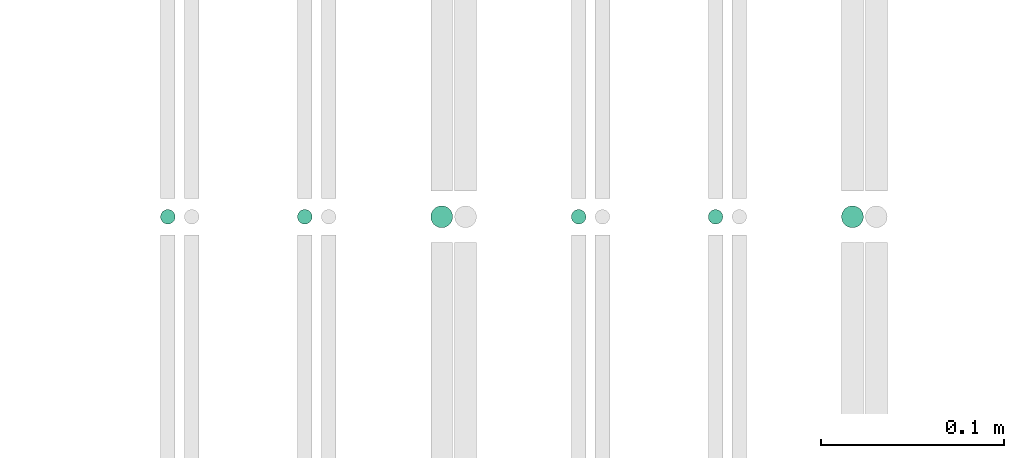
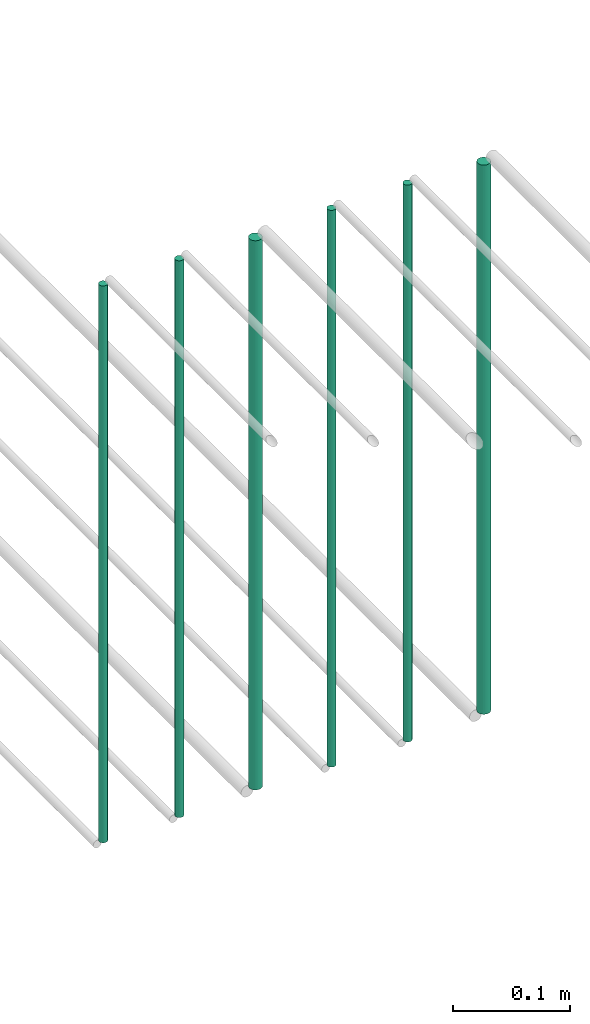
# One storey, part 145 of 331: 6 flow segments.
"""IFC2X3 building model written with IfcOpenShell, lengths in millimetres."""

from ifc_helpers import new_model, entity, si_unit, converted_unit, derived_unit, direction, frame, frame_2d, origin, origin_2d_with_axis, place, context, subcontext, project, spatial, circle, extrude, type_object, element, save


model = new_model("IFC2X3")

# Units and contexts
model_context = context("Model", 3, precision=0.01, world=origin(), true_north=direction((6.12303176911189e-17, 1.0)))
body_context = subcontext(model_context, "Body", "Model", "MODEL_VIEW")
ifc_project = project(units=[si_unit("LENGTHUNIT", "METRE", prefix="MILLI"), si_unit("AREAUNIT", "SQUARE_METRE"), si_unit("VOLUMEUNIT", "CUBIC_METRE"), converted_unit("PLANEANGLEUNIT", "DEGREE", entity("IfcRatioMeasure", 0.0174532925199433), si_unit("PLANEANGLEUNIT", "RADIAN"), dimensions=[0, 0, 0, 0, 0, 0, 0]), si_unit("MASSUNIT", "GRAM", prefix="KILO"), derived_unit("MASSDENSITYUNIT", [(si_unit("MASSUNIT", "GRAM", prefix="KILO"), 1), (si_unit("LENGTHUNIT", "METRE"), -3)]), derived_unit("MOMENTOFINERTIAUNIT", [(si_unit("LENGTHUNIT", "METRE"), 4)]), si_unit("TIMEUNIT", "SECOND"), si_unit("FREQUENCYUNIT", "HERTZ"), si_unit("THERMODYNAMICTEMPERATUREUNIT", "DEGREE_CELSIUS"), derived_unit("THERMALTRANSMITTANCEUNIT", [(si_unit("MASSUNIT", "GRAM", prefix="KILO"), 1), (si_unit("THERMODYNAMICTEMPERATUREUNIT", "KELVIN"), -1), (si_unit("TIMEUNIT", "SECOND"), -3)]), derived_unit("VOLUMETRICFLOWRATEUNIT", [(si_unit("LENGTHUNIT", "METRE"), 3), (si_unit("TIMEUNIT", "SECOND"), -1)]), derived_unit("MASSFLOWRATEUNIT", [(si_unit("MASSUNIT", "GRAM", prefix="KILO"), 1), (si_unit("TIMEUNIT", "SECOND"), -1)]), derived_unit("ROTATIONALFREQUENCYUNIT", [(si_unit("TIMEUNIT", "SECOND"), -1)]), si_unit("ELECTRICCURRENTUNIT", "AMPERE"), si_unit("ELECTRICVOLTAGEUNIT", "VOLT"), si_unit("POWERUNIT", "WATT"), si_unit("FORCEUNIT", "NEWTON", prefix="KILO"), si_unit("ILLUMINANCEUNIT", "LUX"), si_unit("LUMINOUSFLUXUNIT", "LUMEN"), si_unit("LUMINOUSINTENSITYUNIT", "CANDELA"), derived_unit("USERDEFINED", [(si_unit("MASSUNIT", "GRAM", prefix="KILO"), -1), (si_unit("LENGTHUNIT", "METRE"), -2), (si_unit("TIMEUNIT", "SECOND"), 3), (si_unit("LUMINOUSFLUXUNIT", "LUMEN"), 1)]), derived_unit("LINEARVELOCITYUNIT", [(si_unit("LENGTHUNIT", "METRE"), 1), (si_unit("TIMEUNIT", "SECOND"), -1)]), si_unit("PRESSUREUNIT", "PASCAL"), derived_unit("USERDEFINED", [(si_unit("LENGTHUNIT", "METRE"), -2), (si_unit("MASSUNIT", "GRAM", prefix="KILO"), 1), (si_unit("TIMEUNIT", "SECOND"), -2)]), derived_unit("LINEARFORCEUNIT", [(si_unit("MASSUNIT", "GRAM", prefix="KILO"), 1), (si_unit("LENGTHUNIT", "METRE"), 1), (si_unit("TIMEUNIT", "SECOND"), -2), (si_unit("LENGTHUNIT", "METRE"), -1)]), derived_unit("PLANARFORCEUNIT", [(si_unit("MASSUNIT", "GRAM", prefix="KILO"), 1), (si_unit("LENGTHUNIT", "METRE"), 1), (si_unit("TIMEUNIT", "SECOND"), -2), (si_unit("LENGTHUNIT", "METRE"), -2)])], contexts=[model_context])

# Site, building, storey
site_placement = place(None, frame((0.0, -0.00077364408347762, 0.0)))
site = spatial("IfcSite", under=ifc_project, at=site_placement, CompositionType="ELEMENT")
building_placement = place(site_placement, origin())
building = spatial("IfcBuilding", under=site, at=building_placement, CompositionType="ELEMENT")
storey_placement = place(building_placement, origin())
storey = spatial("IfcBuildingStorey", under=building, at=storey_placement, CompositionType="ELEMENT", Elevation=0.0)

# Flow segments
pipe_segment_type = type_object("IfcPipeSegmentType", PredefinedType="NOTDEFINED")
flow_segment_1_placement = place(storey_placement, frame((34165.4558773093, 5638.02529159143, 18460.0)))
element("IfcFlowSegment", 1, at=flow_segment_1_placement, inside=storey, type_object=pipe_segment_type, context=body_context, shape_type="SweptSolid", body=[
    extrude(circle(Radius=4.0, at=origin_2d_with_axis()), frame((5.59527223591499, 5.59527223591607, 0.0), z_axis=(0.0, 0.0, 1.0), x_axis=(-1.0, 0.0, 0.0)), (0.0, 0.0, 1.0), 580.000000000015),
])
flow_segment_2_placement = place(storey_placement, frame((34240.4558773093, 5638.02529159143, 18460.0)))
element("IfcFlowSegment", 2, at=flow_segment_2_placement, inside=storey, type_object=pipe_segment_type, context=body_context, shape_type="SweptSolid", body=[
    extrude(circle(Radius=4.0, at=origin_2d_with_axis()), frame((5.59527223591499, 5.59527223591607, 0.0), z_axis=(0.0, 0.0, 1.0), x_axis=(-1.0, 0.0, 0.0)), (0.0, 0.0, 1.0), 580.000000000007),
])
flow_segment_3_placement = place(storey_placement, frame((34313.4558773093, 5636.02529159143, 18464.0)))
element("IfcFlowSegment", 3, at=flow_segment_3_placement, inside=storey, type_object=pipe_segment_type, context=body_context, shape_type="SweptSolid", body=[
    extrude(circle(Radius=6.0, at=origin_2d_with_axis()), frame((7.59527223591454, 7.59527223591562, 0.0), z_axis=(0.0, 0.0, 1.0), x_axis=(-1.0, 0.0, 0.0)), (0.0, 0.0, 1.0), 572.000000000002),
])
flow_segment_4_placement = place(storey_placement, frame((34390.4558773093, 5638.02529159143, 18460.0)))
element("IfcFlowSegment", 4, at=flow_segment_4_placement, inside=storey, type_object=pipe_segment_type, context=body_context, shape_type="SweptSolid", body=[
    extrude(circle(Radius=4.0, at=origin_2d_with_axis()), frame((5.59527223591499, 5.59527223591607, 0.0), z_axis=(0.0, 0.0, 1.0), x_axis=(-1.0, 0.0, 0.0)), (0.0, 0.0, 1.0), 580.000000000015),
])
flow_segment_5_placement = place(storey_placement, frame((34465.4558773093, 5638.02529159143, 18460.0)))
element("IfcFlowSegment", 5, at=flow_segment_5_placement, inside=storey, type_object=pipe_segment_type, context=body_context, shape_type="SweptSolid", body=[
    extrude(circle(Radius=4.0, at=frame_2d((0.0, -1.08286712929839e-12), x_axis=(1.0, 0.0))), frame((5.59527223591499, 5.59527223591499, 0.0), z_axis=(0.0, 0.0, 1.0), x_axis=(-1.0, 0.0, 0.0)), (0.0, 0.0, 1.0), 580.0),
])
flow_segment_6_placement = place(storey_placement, frame((34538.4558773093, 5636.02529159144, 18464.0)))
element("IfcFlowSegment", 6, at=flow_segment_6_placement, inside=storey, type_object=pipe_segment_type, context=body_context, shape_type="SweptSolid", body=[
    extrude(circle(Radius=6.0, at=origin_2d_with_axis()), frame((7.59527223591454, 7.59527223591562, 0.0), z_axis=(0.0, 0.0, 1.0), x_axis=(-1.0, 0.0, 0.0)), (0.0, 0.0, 1.0), 572.000000000011),
])

save(model, "model.ifc")
